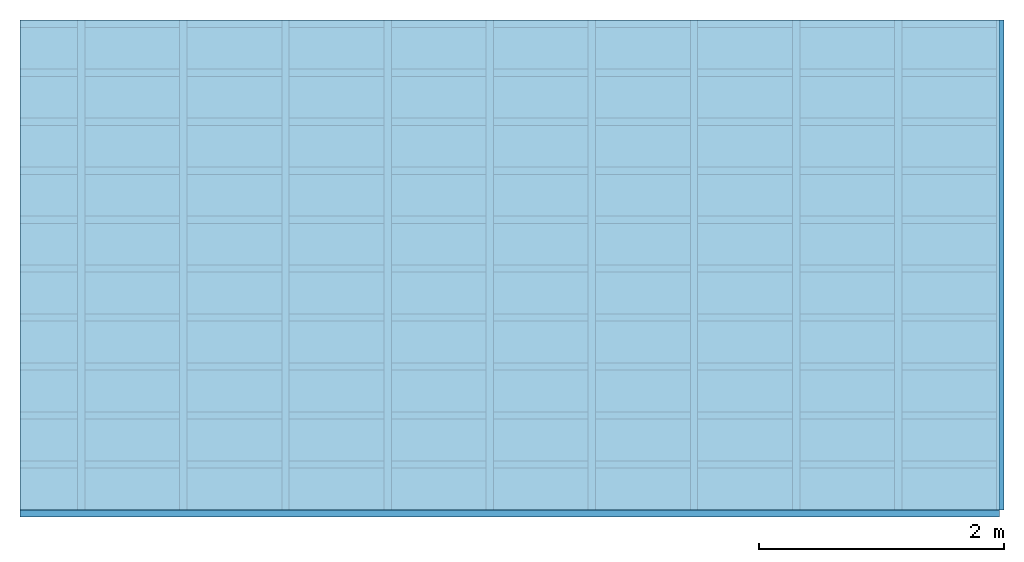
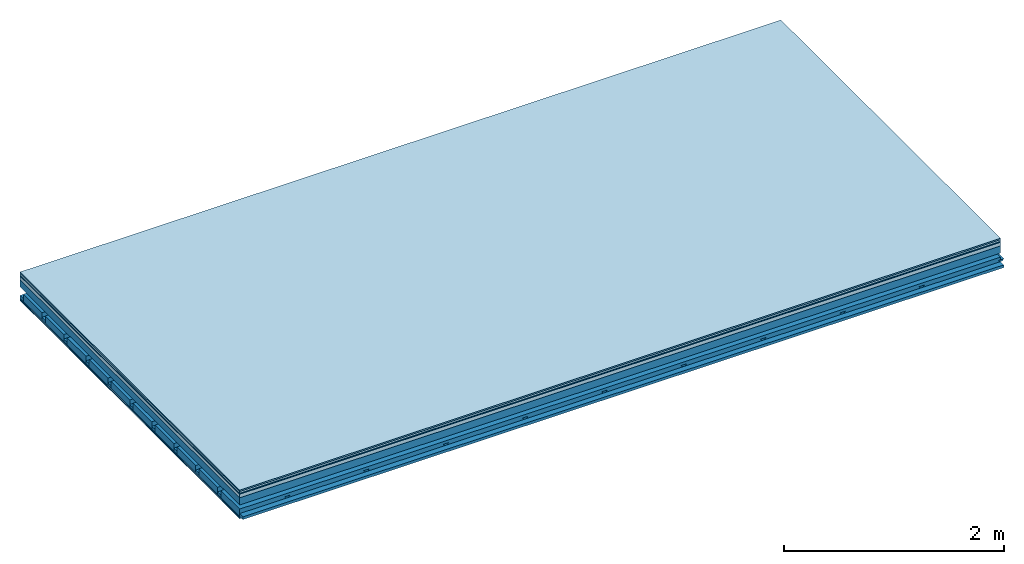
# One storey: 7 plates, 4 members, 1 element without a shape of its own.
"""IFC4 building model written with IfcOpenShell, lengths in metres."""

from ifc_helpers import new_model, si_unit, derived_unit, direction, frame, frame_2d, origin, origin_with_axes, place, context, project, spatial, polyline, rectangle, outline, extrude, material, layer, layer_set, type_object, element, aggregate, save


model = new_model("IFC4")

# Units and contexts
plan_context = context("Plan", 3, precision=1e-05, world=origin(), true_north=direction((0.0, 1.0)))
model_context = context("Model", 3, precision=1e-05, world=origin(), true_north=direction((0.0, 1.0)))
ifc_project = project(units=[si_unit("LENGTHUNIT", "METRE"), derived_unit("SOUNDPRESSUREUNIT", [(si_unit("PRESSUREUNIT", "PASCAL", prefix="MICRO"), 0)]), si_unit("ENERGYUNIT", "JOULE", prefix="MEGA"), si_unit("MASSUNIT", "GRAM", prefix="KILO"), derived_unit("THERMALTRANSMITTANCEUNIT", [(si_unit("POWERUNIT", "WATT"), 1), (si_unit("AREAUNIT", "SQUARE_METRE"), -1), (si_unit("THERMODYNAMICTEMPERATUREUNIT", "KELVIN"), -1)]), derived_unit("AREADENSITYUNIT", [(si_unit("MASSUNIT", "GRAM", prefix="KILO"), 1), (si_unit("AREAUNIT", "SQUARE_METRE"), -1)]), derived_unit("USERDEFINED", [(si_unit("ENERGYUNIT", "JOULE", prefix="MEGA"), 1), (si_unit("AREAUNIT", "SQUARE_METRE"), -1)])], contexts=[plan_context, model_context])

# Site, building, storey
site = spatial("IfcSite", under=ifc_project)
building_placement = place(None, origin())
building = spatial("IfcBuilding", under=site, at=building_placement)
storey_placement = place(building_placement, origin())
storey = spatial("IfcBuildingStorey", under=building, at=storey_placement)

# Slab, members, plates
ifc_material_1 = material(Category="11.013")
ifc_layer_1 = layer(ifc_material_1, 0.015, Name="Flooring")
ifc_material_2 = material(Category="03.007")
ifc_layer_2 = layer(ifc_material_2, 0.02, Name="On-material")
ifc_material_3 = material(Name="Wood fiber generic product", Category="10.009")
ifc_layer_3 = layer(ifc_material_3, 0.01, Name="Impact sound insulation")
ifc_material_4 = material(Name="Concrete panels", Category="02.007")
ifc_layer_4 = layer(ifc_material_4, 0.04, Name="on Supporting structure")
ifc_material_5 = material(Name="no composite action")
ifc_layer_5 = layer(ifc_material_5, 0.0, Name="Bond")
ifc_layer_6 = layer(None, 0.08, Name="Supporting structure")
ifc_layer_7 = layer(ifc_material_5, 0.0, Name="Bond")
ifc_layer_8 = layer(None, 0.095, Name="Coupling")
ifc_layer_9 = layer(None, 0.03, Name="Battens / profiles")
ifc_material_6 = material(Name="Plasterboard type A", Category="03.008")
ifc_layer_10 = layer(ifc_material_6, 0.0125, Name="Ceiling covering 1st layer")
ifc_layer_11 = layer(ifc_material_6, 0.0125, Name="Ceiling covering layer 2")
ifc_material_7 = material(Category="04.001")
ifc_layer_12 = layer(ifc_material_7, 0.003, Name="Surface / treatment")
ifc_layer_set = layer_set([ifc_layer_1, ifc_layer_2, ifc_layer_3, ifc_layer_4, ifc_layer_5, ifc_layer_6, ifc_layer_7, ifc_layer_8, ifc_layer_9, ifc_layer_10, ifc_layer_11, ifc_layer_12])
slab_type = type_object("IfcSlabType", Name="A2130", PredefinedType="NOTDEFINED", material=ifc_layer_set)
slab_placement = place(None, frame((0.0, 0.0, 0.0), z_axis=(0.0, 0.0, -1.0), x_axis=(1.0, 0.0, 0.0)))
slab = element("IfcSlab", 1, at=slab_placement, inside=storey, type_object=slab_type, material=ifc_layer_set, Name="Slab #1")
ifc_material_8 = material(Name="Solid timber panel")
member_1_placement = place(slab_placement, origin())
member_1 = element("IfcMember", 2, at=member_1_placement, material=ifc_material_8, Name="Supporting structure", context=plan_context, shape_type="SweptSolid", body=[
    extrude(rectangle(XDim=1.0, YDim=0.08, at=frame_2d((0.5, 0.04), x_axis=(1.0, 0.0))), frame((0.0, 4.0, 0.085), z_axis=(0.0, -1.0, 0.0), x_axis=(1.0, 0.0, 0.0)), (0.0, 0.0, 1.0), 4.0),
    extrude(rectangle(XDim=1.0, YDim=0.08, at=frame_2d((0.5, 0.04), x_axis=(1.0, 0.0))), frame((1.0, 4.0, 0.085), z_axis=(0.0, -1.0, 0.0), x_axis=(1.0, 0.0, 0.0)), (0.0, 0.0, 1.0), 4.0),
    extrude(rectangle(XDim=1.0, YDim=0.08, at=frame_2d((0.5, 0.04), x_axis=(1.0, 0.0))), frame((2.0, 4.0, 0.085), z_axis=(0.0, -1.0, 0.0), x_axis=(1.0, 0.0, 0.0)), (0.0, 0.0, 1.0), 4.0),
    extrude(rectangle(XDim=1.0, YDim=0.08, at=frame_2d((0.5, 0.04), x_axis=(1.0, 0.0))), frame((3.0, 4.0, 0.085), z_axis=(0.0, -1.0, 0.0), x_axis=(1.0, 0.0, 0.0)), (0.0, 0.0, 1.0), 4.0),
    extrude(rectangle(XDim=1.0, YDim=0.08, at=frame_2d((0.5, 0.04), x_axis=(1.0, 0.0))), frame((4.0, 4.0, 0.085), z_axis=(0.0, -1.0, 0.0), x_axis=(1.0, 0.0, 0.0)), (0.0, 0.0, 1.0), 4.0),
    extrude(rectangle(XDim=1.0, YDim=0.08, at=frame_2d((0.5, 0.04), x_axis=(1.0, 0.0))), frame((5.0, 4.0, 0.085), z_axis=(0.0, -1.0, 0.0), x_axis=(1.0, 0.0, 0.0)), (0.0, 0.0, 1.0), 4.0),
    extrude(rectangle(XDim=1.0, YDim=0.08, at=frame_2d((0.5, 0.04), x_axis=(1.0, 0.0))), frame((6.0, 4.0, 0.085), z_axis=(0.0, -1.0, 0.0), x_axis=(1.0, 0.0, 0.0)), (0.0, 0.0, 1.0), 4.0),
    extrude(rectangle(XDim=1.0, YDim=0.08, at=frame_2d((0.5, 0.04), x_axis=(1.0, 0.0))), frame((7.0, 4.0, 0.085), z_axis=(0.0, -1.0, 0.0), x_axis=(1.0, 0.0, 0.0)), (0.0, 0.0, 1.0), 4.0),
])
ifc_material_9 = material()
member_2_placement = place(slab_placement, origin())
member_2 = element("IfcMember", 3, at=member_2_placement, material=ifc_material_9, Name="Coupling", context=plan_context, shape_type="SweptSolid", body=[
    extrude(outline(polyline([(0.0, 0.0), (0.06, 0.0), (0.04, 0.02), (0.02, 0.02), (0.0, 0.0)])), frame((0.47, 4.0, 0.24), z_axis=(0.0, -1.0, 0.0), x_axis=(1.0, 0.0, 0.0)), (0.0, 0.0, 1.0), 4.0),
    extrude(outline(polyline([(0.0, 0.0), (0.06, 0.0), (0.04, 0.02), (0.02, 0.02), (0.0, 0.0)])), frame((1.304, 4.0, 0.24), z_axis=(0.0, -1.0, 0.0), x_axis=(1.0, 0.0, 0.0)), (0.0, 0.0, 1.0), 4.0),
    extrude(outline(polyline([(0.0, 0.0), (0.06, 0.0), (0.04, 0.02), (0.02, 0.02), (0.0, 0.0)])), frame((2.138, 4.0, 0.24), z_axis=(0.0, -1.0, 0.0), x_axis=(1.0, 0.0, 0.0)), (0.0, 0.0, 1.0), 4.0),
    extrude(outline(polyline([(0.0, 0.0), (0.06, 0.0), (0.04, 0.02), (0.02, 0.02), (0.0, 0.0)])), frame((2.972, 4.0, 0.24), z_axis=(0.0, -1.0, 0.0), x_axis=(1.0, 0.0, 0.0)), (0.0, 0.0, 1.0), 4.0),
    extrude(outline(polyline([(0.0, 0.0), (0.06, 0.0), (0.04, 0.02), (0.02, 0.02), (0.0, 0.0)])), frame((3.806, 4.0, 0.24), z_axis=(0.0, -1.0, 0.0), x_axis=(1.0, 0.0, 0.0)), (0.0, 0.0, 1.0), 4.0),
    extrude(outline(polyline([(0.0, 0.0), (0.06, 0.0), (0.04, 0.02), (0.02, 0.02), (0.0, 0.0)])), frame((4.64, 4.0, 0.24), z_axis=(0.0, -1.0, 0.0), x_axis=(1.0, 0.0, 0.0)), (0.0, 0.0, 1.0), 4.0),
    extrude(outline(polyline([(0.0, 0.0), (0.06, 0.0), (0.04, 0.02), (0.02, 0.02), (0.0, 0.0)])), frame((5.474, 4.0, 0.24), z_axis=(0.0, -1.0, 0.0), x_axis=(1.0, 0.0, 0.0)), (0.0, 0.0, 1.0), 4.0),
    extrude(outline(polyline([(0.0, 0.0), (0.06, 0.0), (0.04, 0.02), (0.02, 0.02), (0.0, 0.0)])), frame((6.308, 4.0, 0.24), z_axis=(0.0, -1.0, 0.0), x_axis=(1.0, 0.0, 0.0)), (0.0, 0.0, 1.0), 4.0),
    extrude(outline(polyline([(0.0, 0.0), (0.06, 0.0), (0.04, 0.02), (0.02, 0.02), (0.0, 0.0)])), frame((7.142, 4.0, 0.24), z_axis=(0.0, -1.0, 0.0), x_axis=(1.0, 0.0, 0.0)), (0.0, 0.0, 1.0), 4.0),
    extrude(outline(polyline([(0.0, 0.0), (0.06, 0.0), (0.04, 0.02), (0.02, 0.02), (0.0, 0.0)])), frame((7.976, 4.0, 0.24), z_axis=(0.0, -1.0, 0.0), x_axis=(1.0, 0.0, 0.0)), (0.0, 0.0, 1.0), 4.0),
])
member_3_placement = place(slab_placement, origin())
member_3 = element("IfcMember", 4, at=member_3_placement, material=ifc_material_9, Name="Battens / profiles", context=plan_context, shape_type="SweptSolid", body=[
    extrude(rectangle(XDim=0.06, YDim=0.03, at=frame_2d((0.03, 0.015), x_axis=(1.0, 0.0))), frame((0.0, 0.0, 0.26), z_axis=(1.0, 0.0, 0.0), x_axis=(0.0, 1.0, 0.0)), (0.0, 0.0, 1.0), 8.0),
    extrude(rectangle(XDim=0.06, YDim=0.03, at=frame_2d((0.03, 0.015), x_axis=(1.0, 0.0))), frame((0.0, 0.4, 0.26), z_axis=(1.0, 0.0, 0.0), x_axis=(0.0, 1.0, 0.0)), (0.0, 0.0, 1.0), 8.0),
    extrude(rectangle(XDim=0.06, YDim=0.03, at=frame_2d((0.03, 0.015), x_axis=(1.0, 0.0))), frame((0.0, 0.8, 0.26), z_axis=(1.0, 0.0, 0.0), x_axis=(0.0, 1.0, 0.0)), (0.0, 0.0, 1.0), 8.0),
    extrude(rectangle(XDim=0.06, YDim=0.03, at=frame_2d((0.03, 0.015), x_axis=(1.0, 0.0))), frame((0.0, 1.2, 0.26), z_axis=(1.0, 0.0, 0.0), x_axis=(0.0, 1.0, 0.0)), (0.0, 0.0, 1.0), 8.0),
    extrude(rectangle(XDim=0.06, YDim=0.03, at=frame_2d((0.03, 0.015), x_axis=(1.0, 0.0))), frame((0.0, 1.6, 0.26), z_axis=(1.0, 0.0, 0.0), x_axis=(0.0, 1.0, 0.0)), (0.0, 0.0, 1.0), 8.0),
    extrude(rectangle(XDim=0.06, YDim=0.03, at=frame_2d((0.03, 0.015), x_axis=(1.0, 0.0))), frame((0.0, 2.0, 0.26), z_axis=(1.0, 0.0, 0.0), x_axis=(0.0, 1.0, 0.0)), (0.0, 0.0, 1.0), 8.0),
    extrude(rectangle(XDim=0.06, YDim=0.03, at=frame_2d((0.03, 0.015), x_axis=(1.0, 0.0))), frame((0.0, 2.4, 0.26), z_axis=(1.0, 0.0, 0.0), x_axis=(0.0, 1.0, 0.0)), (0.0, 0.0, 1.0), 8.0),
    extrude(rectangle(XDim=0.06, YDim=0.03, at=frame_2d((0.03, 0.015), x_axis=(1.0, 0.0))), frame((0.0, 2.8, 0.26), z_axis=(1.0, 0.0, 0.0), x_axis=(0.0, 1.0, 0.0)), (0.0, 0.0, 1.0), 8.0),
    extrude(rectangle(XDim=0.06, YDim=0.03, at=frame_2d((0.03, 0.015), x_axis=(1.0, 0.0))), frame((0.0, 3.2, 0.26), z_axis=(1.0, 0.0, 0.0), x_axis=(0.0, 1.0, 0.0)), (0.0, 0.0, 1.0), 8.0),
    extrude(rectangle(XDim=0.06, YDim=0.03, at=frame_2d((0.03, 0.015), x_axis=(1.0, 0.0))), frame((0.0, 3.6, 0.26), z_axis=(1.0, 0.0, 0.0), x_axis=(0.0, 1.0, 0.0)), (0.0, 0.0, 1.0), 8.0),
    extrude(rectangle(XDim=0.06, YDim=0.03, at=frame_2d((0.03, 0.015), x_axis=(1.0, 0.0))), frame((0.0, 4.0, 0.26), z_axis=(1.0, 0.0, 0.0), x_axis=(0.0, 1.0, 0.0)), (0.0, 0.0, 1.0), 8.0),
])
ifc_material_10 = material()
member_4_placement = place(slab_placement, origin())
member_4 = element("IfcMember", 5, at=member_4_placement, material=ifc_material_10, Name="Cavity", context=plan_context, shape_type="SweptSolid", body=[
    extrude(rectangle(XDim=0.34, YDim=0.08, at=frame_2d((0.17, 0.04), x_axis=(1.0, 0.0))), frame((0.0, 0.06, 0.21), z_axis=(1.0, 0.0, 0.0), x_axis=(0.0, 1.0, 0.0)), (0.0, 0.0, 1.0), 8.0),
    extrude(rectangle(XDim=0.34, YDim=0.08, at=frame_2d((0.17, 0.04), x_axis=(1.0, 0.0))), frame((0.0, 0.46, 0.21), z_axis=(1.0, 0.0, 0.0), x_axis=(0.0, 1.0, 0.0)), (0.0, 0.0, 1.0), 8.0),
    extrude(rectangle(XDim=0.34, YDim=0.08, at=frame_2d((0.17, 0.04), x_axis=(1.0, 0.0))), frame((0.0, 0.86, 0.21), z_axis=(1.0, 0.0, 0.0), x_axis=(0.0, 1.0, 0.0)), (0.0, 0.0, 1.0), 8.0),
    extrude(rectangle(XDim=0.34, YDim=0.08, at=frame_2d((0.17, 0.04), x_axis=(1.0, 0.0))), frame((0.0, 1.26, 0.21), z_axis=(1.0, 0.0, 0.0), x_axis=(0.0, 1.0, 0.0)), (0.0, 0.0, 1.0), 8.0),
    extrude(rectangle(XDim=0.34, YDim=0.08, at=frame_2d((0.17, 0.04), x_axis=(1.0, 0.0))), frame((0.0, 1.66, 0.21), z_axis=(1.0, 0.0, 0.0), x_axis=(0.0, 1.0, 0.0)), (0.0, 0.0, 1.0), 8.0),
    extrude(rectangle(XDim=0.34, YDim=0.08, at=frame_2d((0.17, 0.04), x_axis=(1.0, 0.0))), frame((0.0, 2.06, 0.21), z_axis=(1.0, 0.0, 0.0), x_axis=(0.0, 1.0, 0.0)), (0.0, 0.0, 1.0), 8.0),
    extrude(rectangle(XDim=0.34, YDim=0.08, at=frame_2d((0.17, 0.04), x_axis=(1.0, 0.0))), frame((0.0, 2.46, 0.21), z_axis=(1.0, 0.0, 0.0), x_axis=(0.0, 1.0, 0.0)), (0.0, 0.0, 1.0), 8.0),
    extrude(rectangle(XDim=0.34, YDim=0.08, at=frame_2d((0.17, 0.04), x_axis=(1.0, 0.0))), frame((0.0, 2.86, 0.21), z_axis=(1.0, 0.0, 0.0), x_axis=(0.0, 1.0, 0.0)), (0.0, 0.0, 1.0), 8.0),
    extrude(rectangle(XDim=0.34, YDim=0.08, at=frame_2d((0.17, 0.04), x_axis=(1.0, 0.0))), frame((0.0, 3.26, 0.21), z_axis=(1.0, 0.0, 0.0), x_axis=(0.0, 1.0, 0.0)), (0.0, 0.0, 1.0), 8.0),
    extrude(rectangle(XDim=0.34, YDim=0.08, at=frame_2d((0.17, 0.04), x_axis=(1.0, 0.0))), frame((0.0, 3.66, 0.21), z_axis=(1.0, 0.0, 0.0), x_axis=(0.0, 1.0, 0.0)), (0.0, 0.0, 1.0), 8.0),
])
plate_1_placement = place(slab_placement, origin())
plate_1 = element("IfcPlate", 6, at=plate_1_placement, material=ifc_material_1, Name="Flooring", context=plan_context, shape_type="SweptSolid", body=[
    extrude(rectangle(XDim=8.0, YDim=4.0, at=frame_2d((4.0, 2.0), x_axis=(1.0, 0.0))), origin_with_axes(), (0.0, 0.0, 1.0), 0.015),
])
plate_2_placement = place(slab_placement, origin())
plate_2 = element("IfcPlate", 7, at=plate_2_placement, material=ifc_material_2, Name="On-material", context=plan_context, shape_type="SweptSolid", body=[
    extrude(rectangle(XDim=8.0, YDim=4.0, at=frame_2d((4.0, 2.0), x_axis=(1.0, 0.0))), frame((0.0, 0.0, 0.015), z_axis=(0.0, 0.0, 1.0), x_axis=(1.0, 0.0, 0.0)), (0.0, 0.0, 1.0), 0.02),
])
plate_3_placement = place(slab_placement, origin())
plate_3 = element("IfcPlate", 8, at=plate_3_placement, material=ifc_material_3, Name="Impact sound insulation", context=plan_context, shape_type="SweptSolid", body=[
    extrude(rectangle(XDim=8.0, YDim=4.0, at=frame_2d((4.0, 2.0), x_axis=(1.0, 0.0))), frame((0.0, 0.0, 0.035), z_axis=(0.0, 0.0, 1.0), x_axis=(1.0, 0.0, 0.0)), (0.0, 0.0, 1.0), 0.01),
])
plate_4_placement = place(slab_placement, origin())
plate_4 = element("IfcPlate", 9, at=plate_4_placement, material=ifc_material_4, Name="on Supporting structure", context=plan_context, shape_type="SweptSolid", body=[
    extrude(rectangle(XDim=8.0, YDim=4.0, at=frame_2d((4.0, 2.0), x_axis=(1.0, 0.0))), frame((0.0, 0.0, 0.045), z_axis=(0.0, 0.0, 1.0), x_axis=(1.0, 0.0, 0.0)), (0.0, 0.0, 1.0), 0.04),
])
plate_5_placement = place(slab_placement, origin())
plate_5 = element("IfcPlate", 10, at=plate_5_placement, material=ifc_material_6, Name="Ceiling covering 1st layer", context=plan_context, shape_type="SweptSolid", body=[
    extrude(rectangle(XDim=8.0, YDim=4.0, at=frame_2d((4.0, 2.0), x_axis=(1.0, 0.0))), frame((0.0, 0.0, 0.29), z_axis=(0.0, 0.0, 1.0), x_axis=(1.0, 0.0, 0.0)), (0.0, 0.0, 1.0), 0.0125),
])
plate_6_placement = place(slab_placement, origin())
plate_6 = element("IfcPlate", 11, at=plate_6_placement, material=ifc_material_6, Name="Ceiling covering layer 2", context=plan_context, shape_type="SweptSolid", body=[
    extrude(rectangle(XDim=8.0, YDim=4.0, at=frame_2d((4.0, 2.0), x_axis=(1.0, 0.0))), frame((0.0, 0.0, 0.3025), z_axis=(0.0, 0.0, 1.0), x_axis=(1.0, 0.0, 0.0)), (0.0, 0.0, 1.0), 0.0125),
])
plate_7_placement = place(slab_placement, origin())
plate_7 = element("IfcPlate", 12, at=plate_7_placement, material=ifc_material_7, Name="Surface / treatment", context=plan_context, shape_type="SweptSolid", body=[
    extrude(rectangle(XDim=8.0, YDim=4.0, at=frame_2d((4.0, 2.0), x_axis=(1.0, 0.0))), frame((0.0, 0.0, 0.315), z_axis=(0.0, 0.0, 1.0), x_axis=(1.0, 0.0, 0.0)), (0.0, 0.0, 1.0), 0.003),
])
aggregate(slab, [plate_1, plate_2, plate_3, plate_4, member_1, member_2, member_3, member_4, plate_5, plate_6, plate_7])

save(model, "model.ifc")
